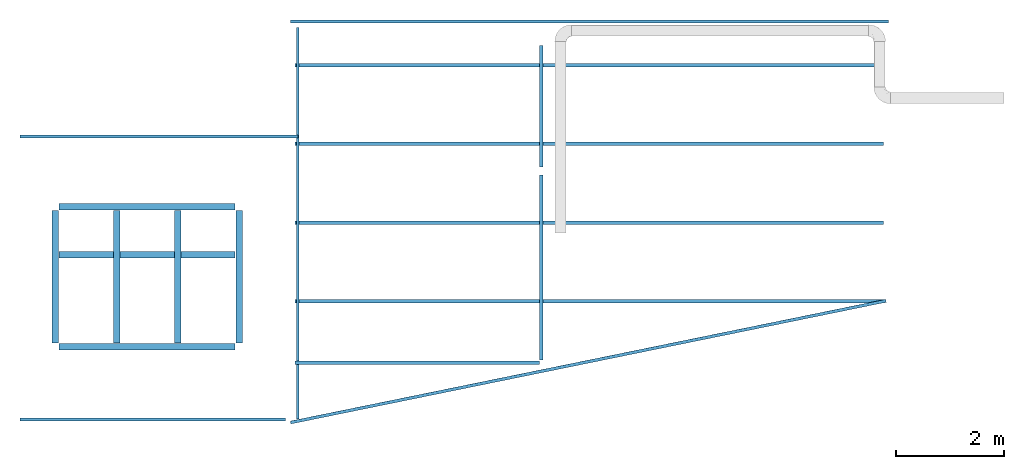
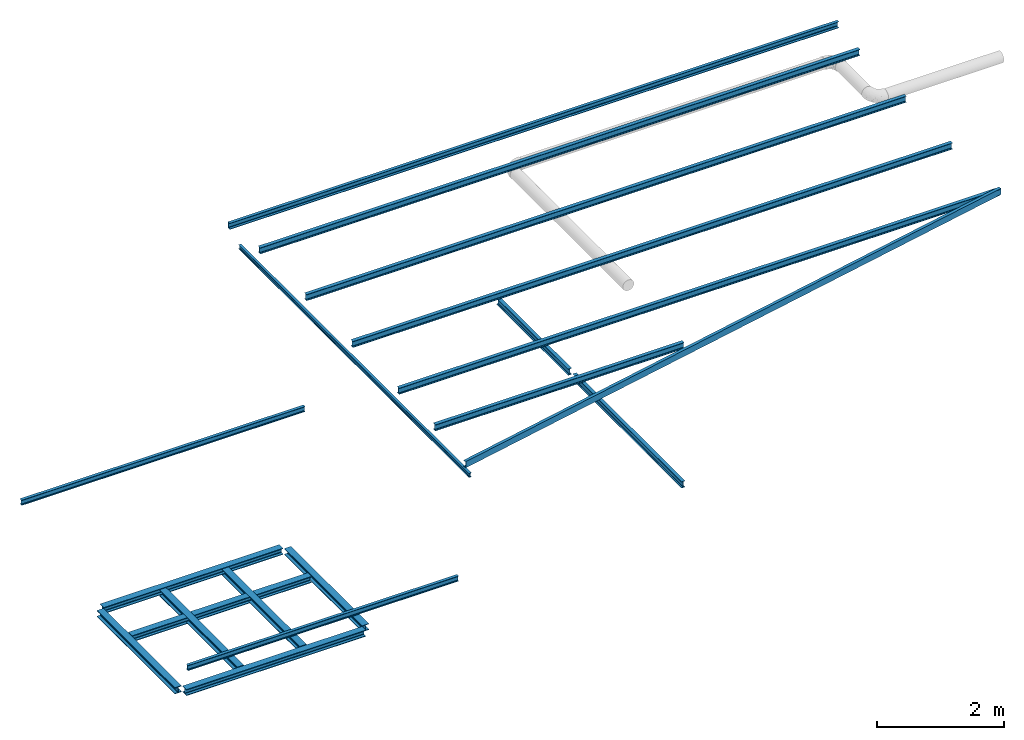
# One storey, part 1 of 2: 15 beams, 4 members.
"""IFC2X3 building model written with IfcOpenShell, lengths in metres."""

from ifc_helpers import new_model, entity, si_unit, converted_unit, derived_unit, direction, frame, frame_2d, origin, place, context, subcontext, project, spatial, polyline, circle_curve, parameter, trimmed, segment, composite_curve, i_section, outline, extrude, source, transform, mapped, material, type_object, type_shapes, element, save


model = new_model("IFC2X3")

# Units and contexts
model_context = context("Model", 3, precision=1e-05, world=origin(), true_north=direction((6.123233995736766e-17, 1.0)))
body_context = subcontext(model_context, "Body", "Model", "MODEL_VIEW")
ifc_project = project(units=[si_unit("LENGTHUNIT", "METRE"), converted_unit("PLANEANGLEUNIT", "DEGREE", entity("IfcPlaneAngleMeasure", 0.017453292519943278), si_unit("PLANEANGLEUNIT", "RADIAN"), dimensions=[0, 0, 0, 0, 0, 0, 0]), si_unit("AREAUNIT", "SQUARE_METRE"), derived_unit("THERMALTRANSMITTANCEUNIT", [(si_unit("MASSUNIT", "GRAM", prefix="KILO"), 1), (si_unit("THERMODYNAMICTEMPERATUREUNIT", "KELVIN"), -1), (si_unit("TIMEUNIT", "SECOND"), -3)])], contexts=[model_context])

# Site, building, storey
site_placement = place(None, origin())
site = spatial("IfcSite", under=ifc_project, at=site_placement, CompositionType="ELEMENT")
building_placement = place(site_placement, origin())
building = spatial("IfcBuilding", under=site, at=building_placement, CompositionType="ELEMENT")
storey_placement = place(building_placement, frame((0.0, 0.0, 8.0952)))
storey = spatial("IfcBuildingStorey", under=building, at=storey_placement, Name="2", CompositionType="ELEMENT", Elevation=8.0952)

# Beams
ifc_material = material(Name="Metal - Steel - 345 MPa")
beam_type_1 = type_object("IfcBeamType", PredefinedType="NOTDEFINED")
beam_1_placement = place(storey_placement, frame((0.30669713519211367, -1.5492589967772536, -2.601933788715456), z_axis=(0.0, 0.0, 1.0), x_axis=(0.0, 1.0, 0.0)))
element("IfcBeam", 1, at=beam_1_placement, inside=storey, type_object=beam_type_1, material=ifc_material, context=body_context, shape_type="SweptSolid", body=[
    extrude(i_section(OverallWidth=0.1200000000000002, OverallDepth=0.11999999999999979, WebThickness=0.006500000000000249, FlangeThickness=0.011000000000001831, FilletRadius=0.012000000000000243, at=frame_2d((0.0, 5.204170427930421e-17), x_axis=(0.0, 1.0))), frame((0.0727626166928101, 0.0, -0.060000000000005854), z_axis=(1.0, 0.0, 0.0), x_axis=(0.0, 0.0, -1.0)), (0.0, 0.0, 1.0), 2.448000000000001),
])
beam_2_placement = place(storey_placement, frame((3.7066971351921287, -1.549258996777253, -2.6019337887154657), z_axis=(0.0, 0.0, 1.0), x_axis=(0.0, 1.0, 0.0)))
element("IfcBeam", 2, at=beam_2_placement, inside=storey, type_object=beam_type_1, material=ifc_material, context=body_context, shape_type="SweptSolid", body=[
    extrude(i_section(OverallWidth=0.12000000000000033, OverallDepth=0.12000000000000088, WebThickness=0.006499999999996505, FlangeThickness=0.011000000000001831, FilletRadius=0.012000000000000306, at=frame_2d((1.0824674490095276e-15, 2.706168622523819e-16), x_axis=(0.0, 1.0))), frame((0.07276261669280956, 0.0, -0.06000000000000477), z_axis=(1.0, 0.0, 0.0), x_axis=(0.0, 0.0, -1.0)), (0.0, 0.0, 1.0), 2.448),
])
beam_3_placement = place(storey_placement, frame((0.3066971351921177, 1.0442662366083677, -2.601933788715456)))
element("IfcBeam", 3, at=beam_3_placement, inside=storey, type_object=beam_type_1, material=ifc_material, context=body_context, shape_type="SweptSolid", body=[
    extrude(i_section(OverallWidth=0.12000000000000033, OverallDepth=0.11999999999999979, WebThickness=0.006499999999999236, FlangeThickness=0.011000000000000749, FilletRadius=0.01200000000000017, at=frame_2d((5.412337245047638e-16, -6.591949208711867e-17), x_axis=(0.0, 1.0))), frame((0.07300000000000653, 0.0, -0.060000000000005854), z_axis=(1.0, 0.0, 0.0), x_axis=(0.0, 0.0, -1.0)), (0.0, 0.0, 1.0), 3.2540000000000013),
])
beam_type_2 = type_object("IfcBeamType", PredefinedType="JOIST")
beam_4_placement = place(storey_placement, frame((0.3066971351921132, -1.5492589967772523, -2.601933788715456)))
element("IfcBeam", 4, at=beam_4_placement, inside=storey, type_object=beam_type_2, material=ifc_material, context=body_context, shape_type="SweptSolid", body=[
    extrude(i_section(OverallWidth=0.12000000000000033, OverallDepth=0.11999999999999979, WebThickness=0.006500000000000146, FlangeThickness=0.011000000000000749, FilletRadius=0.012000000000000148, at=frame_2d((5.412337245047638e-16, 0.0), x_axis=(0.0, 1.0))), frame((0.07300000000000723, 0.0, -0.060000000000005854), z_axis=(1.0, 0.0, 0.0), x_axis=(0.0, 0.0, -1.0)), (0.0, 0.0, 1.0), 3.254000000000001),
])
beam_5_placement = place(storey_placement, frame((0.30669713519211717, 0.1525637485110957, -2.601933788715456)))
element("IfcBeam", 5, at=beam_5_placement, inside=storey, type_object=beam_type_2, material=ifc_material, context=body_context, shape_type="SweptSolid", body=[
    extrude(i_section(OverallWidth=0.1200000000000002, OverallDepth=0.11999999999999979, WebThickness=0.006500000000000079, FlangeThickness=0.011000000000000749, FilletRadius=0.012000000000000195, at=frame_2d((5.412337245047638e-16, 3.469446951953614e-17), x_axis=(0.0, 1.0))), frame((0.07300000000000713, 0.0, -0.060000000000005854), z_axis=(1.0, 0.0, 0.0), x_axis=(0.0, 0.0, -1.0)), (0.0, 0.0, 1.0), 3.254000000000001),
])
beam_6_placement = place(storey_placement, frame((1.4400304685255059, 1.0442662366083675, -2.601933788715459), z_axis=(0.0, 0.0, 1.0), x_axis=(0.0, -1.0, 0.0)))
element("IfcBeam", 6, at=beam_6_placement, inside=storey, type_object=beam_type_2, material=ifc_material, context=body_context, shape_type="SweptSolid", body=[
    extrude(i_section(OverallWidth=0.12000000000000006, OverallDepth=0.12000000000000087, WebThickness=0.006500000000000146, FlangeThickness=0.011000000000001831, FilletRadius=0.012000000000001022, at=frame_2d((0.0, 0.0), x_axis=(0.0, 1.0))), frame((0.07276261669281293, 0.0, -0.060000000000005854), z_axis=(1.0, 0.0, 0.0), x_axis=(0.0, 0.0, -1.0)), (0.0, 0.0, 1.0), 2.448),
])
beam_7_placement = place(storey_placement, frame((2.573363801858818, 1.0442662366083635, -2.6019337887154634), z_axis=(0.0, 0.0, 1.0), x_axis=(0.0, -1.0, 0.0)))
element("IfcBeam", 7, at=beam_7_placement, inside=storey, type_object=beam_type_2, material=ifc_material, context=body_context, shape_type="SweptSolid", body=[
    extrude(i_section(OverallWidth=0.11999999999999979, OverallDepth=0.12000000000000088, WebThickness=0.006500000000003789, FlangeThickness=0.011000000000001831, FilletRadius=0.012000000000000966, at=frame_2d((0.0, 2.706168622523819e-16), x_axis=(0.0, 1.0))), frame((0.07276261669281443, 0.0, -0.060000000000005854), z_axis=(1.0, 0.0, 0.0), x_axis=(0.0, 0.0, -1.0)), (0.0, 0.0, 1.0), 2.448),
])
beam_type_3 = type_object("IfcBeamType", Name="IPE-Beams:IPE100", PredefinedType="JOIST")
beam_8_placement = place(storey_placement, frame((4.846697135192188, 2.3395713760116172, -1.0952000000000013), z_axis=(0.0, 0.0, 1.0), x_axis=(-1.0, 0.0, 0.0)))
element("IfcBeam", 8, at=beam_8_placement, inside=storey, type_object=beam_type_3, material=ifc_material, Name="IPE-Beams:IPE100", ObjectType="IPE-Beams:IPE100", context=body_context, shape_type="SweptSolid", body=[
    extrude(i_section(OverallWidth=0.05500000000000049, OverallDepth=0.1, WebThickness=0.004099999999996608, FlangeThickness=0.00570000000000087, FilletRadius=0.006999999999999106, at=frame_2d((5.412337245047638e-16, 4.0592529337857286e-16), x_axis=(0.0, 1.0))), frame((0.04799999999999634, 0.0, -0.050000000000004874), z_axis=(1.0, 0.0, 0.0), x_axis=(0.0, 0.0, -1.0)), (0.0, 0.0, 1.0), 5.144),
])
beam_9_placement = place(storey_placement, frame((4.961936963576227, -2.889258996777291, -1.0952000000000013), z_axis=(0.0, 0.0, 1.0), x_axis=(-1.0, 0.0, 0.0)))
element("IfcBeam", 9, at=beam_9_placement, inside=storey, type_object=beam_type_3, material=ifc_material, Name="IPE-Beams:IPE100", ObjectType="IPE-Beams:IPE100", context=body_context, shape_type="SweptSolid", body=[
    extrude(i_section(OverallWidth=0.05500000000000049, OverallDepth=0.1, WebThickness=0.004099999999999609, FlangeThickness=0.00570000000000087, FilletRadius=0.006999999999999485, at=frame_2d((5.412337245047638e-16, 2.706168622523819e-16), x_axis=(0.0, 1.0))), frame((0.396619914192016, 0.0, -0.050000000000004874), z_axis=(1.0, 0.0, 0.0), x_axis=(0.0, 0.0, -1.0)), (0.0, 0.0, 1.0), 4.911000000000001),
])
beam_type_4 = type_object("IfcBeamType", Name="U-Channels:UPN120", PredefinedType="BEAM")
beam_10_placement = place(storey_placement, frame((4.699182757982756, 4.479421783554592, 1.1754304129694442)))
element("IfcBeam", 10, at=beam_10_placement, inside=storey, type_object=beam_type_4, material=ifc_material, Name="U-Channels:UPN120", ObjectType="U-Channels:UPN120", context=body_context, shape_type="SweptSolid", body=[
    extrude(outline(composite_curve([segment(polyline([(-0.030523524416621532, -0.059999999999999956), (0.024476475583377313, -0.05999999999999995)]), True, "CONTINUOUS"), segment(polyline([(0.024476475583377844, -0.06000000000000104), (0.02447647558337749, -0.05735437703343096)]), True, "CONTINUOUS"), segment(trimmed(circle_curve(frame_2d((0.01997647558337835, -0.0573543770334309), x_axis=(1.0, 0.0)), 0.004499999999999825), [parameter(0.0)], [parameter(85.42607874010409)], True, "PARAMETER"), True, "CONTINUOUS"), segment(polyline([(0.02033532908365046, -0.052868708280017745), (-0.015241231417167954, -0.05002258343995257)]), True, "CONTINUOUS"), segment(trimmed(circle_curve(frame_2d((-0.01452352441662104, -0.04105124593312735), x_axis=(-0.07974522228286952, -0.9968152785361265)), 0.008999999999999654), [parameter(274.57392125989884)], [parameter(0.0)], True, "PARAMETER"), False, "CONTINUOUS"), segment(polyline([(-0.02352352441662149, -0.04105124593312724), (-0.02352352441662143, 0.041051245933134244)]), True, "CONTINUOUS"), segment(trimmed(circle_curve(frame_2d((-0.014523524416620956, 0.04105124593313628), x_axis=(-1.0, 0.0)), 0.008999999999999307), [parameter(274.573921259893)], [parameter(0.0)], True, "PARAMETER"), False, "CONTINUOUS"), segment(polyline([(-0.015241231417166644, 0.05002258343995939), (0.020335329083650863, 0.05286870828002465)]), True, "CONTINUOUS"), segment(trimmed(circle_curve(frame_2d((0.01997647558337966, 0.05735437703343783), x_axis=(0.07974522228262255, -0.9968152785361463)), 0.004499999999999318), [parameter(0.0)], [parameter(85.42607874011394)], True, "PARAMETER"), True, "CONTINUOUS"), segment(polyline([(0.024476475583378267, 0.057354377033437785), (0.024476475583377826, 0.05999999999999921)]), True, "CONTINUOUS"), segment(polyline([(0.024476475583378367, 0.0599999999999992), (-0.030523524416621563, 0.05999999999999921)]), True, "CONTINUOUS"), segment(polyline([(-0.03052352441662047, 0.06000000000000028), (-0.030523524416622073, -0.05999999999999995)]), True, "CONTINUOUS")], self_intersect=False)), frame((-0.03960000000000182, -0.013915416079771502, -0.06014394364196543), z_axis=(1.0, 0.0, 0.0), x_axis=(0.0, -0.9999487637875227, -0.010122736774470394)), (0.0, 0.0, 1.0), 11.052),
])
beam_11_placement = place(storey_placement, frame((15.672439286939504, -0.7074049188185345, 1.1229228412774654), z_axis=(-0.001986929508695549, -0.00040628908034462657, 0.9999979435180408), x_axis=(-0.9797253379532281, -0.20033509231471072, -0.0020280433154477783)))
element("IfcBeam", 11, at=beam_11_placement, inside=storey, type_object=beam_type_4, material=ifc_material, Name="U-Channels:UPN120", ObjectType="U-Channels:UPN120", context=body_context, shape_type="SweptSolid", body=[
    extrude(outline(composite_curve([segment(polyline([(-0.030523524416621896, -0.060000000000003585), (0.024476475583377552, -0.06000000000000286)]), True, "CONTINUOUS"), segment(polyline([(0.02447647558337796, -0.06000000000000285), (0.024476475583377788, -0.05735437703343218)]), True, "CONTINUOUS"), segment(trimmed(circle_curve(frame_2d((0.019976475583377524, -0.05735437703343206), x_axis=(1.0, 0.0)), 0.004499999999999436), [parameter(0.0)], [parameter(85.42607874010774)], True, "PARAMETER"), True, "CONTINUOUS"), segment(polyline([(0.020335329083650287, -0.05286870828001859), (-0.015241231417167586, -0.0500225834399542)]), True, "CONTINUOUS"), segment(trimmed(circle_curve(frame_2d((-0.014523524416622028, -0.04105124593312943), x_axis=(-0.07974522228281967, -0.9968152785361309)), 0.0089999999999995), [parameter(274.5739212598948)], [parameter(0.0)], True, "PARAMETER"), False, "CONTINUOUS"), segment(polyline([(-0.023523524416622033, -0.0410512459331281), (-0.023523524416621706, 0.04105124593313442)]), True, "CONTINUOUS"), segment(trimmed(circle_curve(frame_2d((-0.014523524416620482, 0.041051245933133106), x_axis=(-1.0, 0.0)), 0.009000000000000412), [parameter(274.5739212599046)], [parameter(0.0)], True, "PARAMETER"), False, "CONTINUOUS"), segment(polyline([(-0.015241231417166603, 0.050022583439958454), (0.020335329083650853, 0.0528687082800245)]), True, "CONTINUOUS"), segment(trimmed(circle_curve(frame_2d((0.019976475583377392, 0.05735437703343663), x_axis=(0.07974522228296779, -0.9968152785361192)), 0.00450000000000044), [parameter(0.0)], [parameter(85.42607874009293)], True, "PARAMETER"), True, "CONTINUOUS"), segment(polyline([(0.024476475583378468, 0.05735437703343652), (0.024476475583378662, 0.05999999999999854)]), True, "CONTINUOUS"), segment(polyline([(0.024476475583378662, 0.05999999999999854), (-0.030523524416620516, 0.0599999999999978)]), True, "CONTINUOUS"), segment(polyline([(-0.030523524416620786, 0.0599999999999978), (-0.03052352441662149, -0.06000000000000358)]), True, "CONTINUOUS")], self_intersect=False)), frame((0.0011698148795877962, -0.015117861478290796, -0.059853011835699084), z_axis=(1.0, 0.0, 0.0), x_axis=(0.0, -0.9999508201683447, 0.009917522102572945)), (0.0, 0.0, 1.0), 11.239000000000004),
])

# Members
member_type_1 = type_object("IfcMemberType", Name="IPE-Beams:IPE120", PredefinedType="PURLIN", material=ifc_material)
shared_shape_1 = source(origin(), body_context, "Body", "SweptSolid", [
    extrude(outline(composite_curve([segment(polyline([(-0.03200000000000017, -0.053699999999999734), (-0.03200000000000017, -0.06000000000000053)]), True, "CONTINUOUS"), segment(polyline([(-0.03200000000000017, -0.06000000000000053), (0.03200000000000007, -0.06000000000000053)]), True, "CONTINUOUS"), segment(polyline([(0.03200000000000007, -0.06000000000000053), (0.03200000000000007, -0.053699999999999734)]), True, "CONTINUOUS"), segment(polyline([(0.03200000000000007, -0.053699999999999734), (0.009199999999999969, -0.053699999999999734)]), True, "CONTINUOUS"), segment(trimmed(circle_curve(frame_2d((0.009199999999999955, -0.046699999999999735), x_axis=(1.0, 0.0)), 0.007000000000000001), [parameter(180.00000000000014)], [parameter(269.9999999999999)], True, "PARAMETER"), False, "CONTINUOUS"), segment(polyline([(0.002199999999999953, -0.046699999999999756), (0.002199999999999953, 0.04670000000000016)]), True, "CONTINUOUS"), segment(trimmed(circle_curve(frame_2d((0.009199999999999955, 0.04670000000000014), x_axis=(1.0, 0.0)), 0.007000000000000001), [parameter(90.00000000000009)], [parameter(179.9999999999999)], True, "PARAMETER"), False, "CONTINUOUS"), segment(polyline([(0.009199999999999969, 0.05370000000000012), (0.03200000000000007, 0.05370000000000012)]), True, "CONTINUOUS"), segment(polyline([(0.03200000000000007, 0.05370000000000012), (0.03200000000000007, 0.059999999999999366)]), True, "CONTINUOUS"), segment(polyline([(0.03200000000000006, 0.059999999999999366), (-0.03199999999999961, 0.059999999999999366)]), True, "CONTINUOUS"), segment(polyline([(-0.03199999999999961, 0.059999999999999366), (-0.03199999999999961, 0.05370000000000012)]), True, "CONTINUOUS"), segment(polyline([(-0.03199999999999961, 0.05370000000000012), (-0.009200000000000121, 0.05370000000000012)]), True, "CONTINUOUS"), segment(trimmed(circle_curve(frame_2d((-0.009200000000000132, 0.04670000000000014), x_axis=(1.0, 0.0)), 0.007000000000000001), [parameter(359.99999999999966)], [parameter(89.99999999999973)], True, "PARAMETER"), False, "CONTINUOUS"), segment(polyline([(-0.002200000000000131, 0.046700000000000116), (-0.002200000000000131, -0.046699999999999735)]), True, "CONTINUOUS"), segment(trimmed(circle_curve(frame_2d((-0.009200000000000132, -0.046699999999999735), x_axis=(1.0, 0.0)), 0.007000000000000001), [parameter(269.9999999999999)], [parameter(0.0)], True, "PARAMETER"), False, "CONTINUOUS"), segment(polyline([(-0.009200000000000121, -0.053699999999999734), (-0.03200000000000017, -0.053699999999999734)]), True, "CONTINUOUS")], self_intersect=False)), frame((-5.4415000000000004, 0.0, 0.0), z_axis=(-1.0, 0.0, 0.0), x_axis=(0.0, -1.0, 0.0)), (0.0, 0.0, -1.0), 10.883000000000001),
])
type_shapes(member_type_1, [shared_shape_1])
for number, where, z_axis, x_axis, name in (
    (12, (10.185582757982754, 3.6620022061465747, 1.1071523914458254), (0.0, -0.010122736774463134, 0.9999487637875228), (1.0, 0.0, 0.0), "IPE-Beams:IPE120"),
    (13, (10.185582757982754, 0.7494052619119264, 1.0776674285514138), (0.0, -0.010122736774463134, 0.9999487637875228), (1.0, 0.0, 0.0), "IPE-Beams:IPE120"),
    (14, (10.185582757982745, 2.2057356170887146, 1.092410232758974), (0.0, -0.010122736774463134, 0.9999487637875228), (1.0, 0.0, 0.0), "IPE-Beams:IPE120"),
):
    element("IfcMember", number, at=place(storey_placement, frame(where, z_axis=z_axis, x_axis=x_axis)), inside=storey, type_object=member_type_1, material=ifc_material, Name=name, ObjectType="IPE-Beams:IPE120", context=body_context, shape_type="MappedRepresentation", body=[
        mapped(shared_shape_1, transform((0.0, 0.0, 0.0), scale=1.0)),
    ])

# Beams
beam_type_5 = type_object("IfcBeamType", Name="IPE-Beams:IPE120", PredefinedType="BEAM")
beam_12_placement = place(storey_placement, frame((15.672439286939504, -0.7074049188185346, 1.1229228412774654), z_axis=(0.0, 0.0, 1.0), x_axis=(-1.0, 0.0, 0.0)))
element("IfcBeam", 15, at=beam_12_placement, inside=storey, type_object=beam_type_5, material=ifc_material, Name="IPE-Beams:IPE120", ObjectType="IPE-Beams:IPE120", context=body_context, shape_type="SweptSolid", body=[
    extrude(outline(composite_curve([segment(polyline([(-0.032000000000001284, -0.05369999999999989), (-0.032000000000001506, -0.060000000000000636)]), True, "CONTINUOUS"), segment(polyline([(-0.03200000000000137, -0.060000000000000636), (0.03199999999999873, -0.06000000000000175)]), True, "CONTINUOUS"), segment(polyline([(0.03199999999999887, -0.06000000000000175), (0.031999999999998946, -0.053700000000001004)]), True, "CONTINUOUS"), segment(polyline([(0.031999999999998946, -0.053700000000001004), (0.009199999999998817, -0.053700000000001004)]), True, "CONTINUOUS"), segment(trimmed(circle_curve(frame_2d((0.00919999999999803, -0.0467000000000004), x_axis=(-1.0, 0.0)), 0.006999999999999009), [parameter(0.0)], [parameter(90.00000000001113)], True, "PARAMETER"), False, "CONTINUOUS"), segment(polyline([(0.0021999999999987967, -0.04669999999999984), (0.00220000000000095, 0.04669999999999986)]), True, "CONTINUOUS"), segment(trimmed(circle_curve(frame_2d((0.009200000000000586, 0.046699999999999305), x_axis=(0.0, 1.0)), 0.0069999999999994685), [parameter(0.0)], [parameter(90.00000000000009)], True, "PARAMETER"), False, "CONTINUOUS"), segment(polyline([(0.009200000000001278, 0.05369999999999881), (0.03200000000000128, 0.053699999999998804)]), True, "CONTINUOUS"), segment(polyline([(0.032000000000001416, 0.053699999999998804), (0.032000000000001486, 0.05999999999999847)]), True, "CONTINUOUS"), segment(polyline([(0.032000000000001486, 0.05999999999999847), (-0.03199999999999822, 0.059999999999999575)]), True, "CONTINUOUS"), segment(polyline([(-0.03199999999999822, 0.059999999999999575), (-0.03199999999999842, 0.05369999999999991)]), True, "CONTINUOUS"), segment(polyline([(-0.03199999999999842, 0.05369999999999991), (-0.009199999999998962, 0.053699999999999914)]), True, "CONTINUOUS"), segment(trimmed(circle_curve(frame_2d((-0.009199999999998017, 0.04670000000000148), x_axis=(1.0, 0.0)), 0.0069999999999989515), [parameter(0.0)], [parameter(90.0000000000212)], True, "PARAMETER"), False, "CONTINUOUS"), segment(polyline([(-0.0021999999999990664, 0.046699999999999846), (-0.0022000000000010848, -0.04669999999999987)]), True, "CONTINUOUS"), segment(trimmed(circle_curve(frame_2d((-0.009200000000000721, -0.046699999999999305), x_axis=(0.0, -1.0)), 0.006999999999999463), [parameter(0.0)], [parameter(90.00000000000009)], True, "PARAMETER"), False, "CONTINUOUS"), segment(polyline([(-0.00920000000000129, -0.053699999999999894), (-0.032000000000001284, -0.05369999999999989)]), True, "CONTINUOUS")], self_intersect=False)), frame((0.033128264478370466, -0.0006073642064693182, -0.05999692582725689), z_axis=(-1.0, 0.0, 0.0), x_axis=(0.0, -0.9999487637875225, 0.01012273677448555)), (0.0, 0.0, -1.0), 10.895000000000001),
])
beam_13_placement = place(storey_placement, frame((9.291497135192111, -1.8443540072264035, 1.1114132152199017), z_axis=(0.0, 0.0, 1.0), x_axis=(-1.0, 0.0, 0.0)))
element("IfcBeam", 16, at=beam_13_placement, inside=storey, type_object=beam_type_5, material=ifc_material, Name="IPE-Beams:IPE120", ObjectType="IPE-Beams:IPE120", context=body_context, shape_type="SweptSolid", body=[
    extrude(outline(composite_curve([segment(polyline([(-0.03199999999999899, -0.053700000000000324), (-0.03199999999999877, -0.06000000000000107)]), True, "CONTINUOUS"), segment(polyline([(-0.03199999999999877, -0.06000000000000107), (0.0320000000000016, -0.05999999999999915)]), True, "CONTINUOUS"), segment(polyline([(0.0320000000000016, -0.05999999999999915), (0.03200000000000138, -0.0536999999999984)]), True, "CONTINUOUS"), segment(polyline([(0.03200000000000137, -0.053699999999999484), (0.009200000000001245, -0.053699999999999484)]), True, "CONTINUOUS"), segment(trimmed(circle_curve(frame_2d((0.009199999999999844, -0.046699999999999964), x_axis=(-1.0, 0.0)), 0.006999999999998942), [parameter(0.0)], [parameter(90.0000000000201)], True, "PARAMETER"), False, "CONTINUOUS"), segment(polyline([(0.002200000000000882, -0.046699999999999735), (0.002199999999998605, 0.04670000000000105)]), True, "CONTINUOUS"), segment(trimmed(circle_curve(frame_2d((0.009199999999998107, 0.04670000000000084), x_axis=(0.0, 1.0)), 0.006999999999999453), [parameter(0.0)], [parameter(90.00000000000227)], True, "PARAMETER"), False, "CONTINUOUS"), segment(polyline([(0.009199999999998602, 0.05370000000000033), (0.03199999999999873, 0.05370000000000141)]), True, "CONTINUOUS"), segment(polyline([(0.03199999999999873, 0.05370000000000141), (0.0319999999999985, 0.06000000000000108)]), True, "CONTINUOUS"), segment(polyline([(0.03199999999999822, 0.06), (-0.03200000000000133, 0.059999999999999144)]), True, "CONTINUOUS"), segment(polyline([(-0.03200000000000135, 0.05999999999999806), (-0.032000000000001104, 0.053699999999999484)]), True, "CONTINUOUS"), segment(polyline([(-0.032000000000001104, 0.053699999999999484), (-0.009200000000001506, 0.05370000000000057)]), True, "CONTINUOUS"), segment(trimmed(circle_curve(frame_2d((-0.009200000000000364, 0.046700000000002136), x_axis=(1.0, 0.0)), 0.0069999999999989515), [parameter(0.0)], [parameter(90.0000000000201)], True, "PARAMETER"), False, "CONTINUOUS"), segment(polyline([(-0.002200000000001412, 0.04670000000000083), (-0.0021999999999991245, -0.04669999999999889)]), True, "CONTINUOUS"), segment(trimmed(circle_curve(frame_2d((-0.009199999999998628, -0.04669999999999866), x_axis=(0.0, -1.0)), 0.006999999999999447), [parameter(0.0)], [parameter(90.00000000000227)], True, "PARAMETER"), False, "CONTINUOUS"), segment(polyline([(-0.009199999999998872, -0.05370000000000033), (-0.03199999999999899, -0.053700000000000324)]), True, "CONTINUOUS")], self_intersect=False)), frame((0.03215718860462186, -0.0006073642064693182, -0.05999692582725689), z_axis=(-1.0, 0.0, 0.0), x_axis=(0.0, -0.9999487637875231, 0.010122736774438002)), (0.0, 0.0, -1.0), 4.515),
])
beam_14_placement = place(storey_placement, frame((9.291497135192152, 1.700510500280605, -1.6752771077183575), z_axis=(0.0, 0.0, 1.0), x_axis=(0.0, -1.0, 0.0)))
element("IfcBeam", 17, at=beam_14_placement, inside=storey, type_object=beam_type_5, material=ifc_material, Name="IPE-Beams:IPE120", ObjectType="IPE-Beams:IPE120", context=body_context, shape_type="SweptSolid", body=[
    extrude(i_section(OverallWidth=0.06399999999999953, OverallDepth=0.11999999999999979, WebThickness=0.004400000000000083, FlangeThickness=0.006300000000000734, FilletRadius=0.006999999999998254, at=frame_2d((5.412337245047638e-16, 3.247402347028583e-15), x_axis=(0.0, 1.0))), frame((0.07299413392219276, 0.0, 0.0), z_axis=(1.0, 0.0, 0.0), x_axis=(0.0, 0.0, -1.0)), (0.0, 0.0, 1.0), 3.419000000000001),
])
beam_type_6 = type_object("IfcBeamType", Name="IPE-Beams:IPE120", PredefinedType="NOTDEFINED")
beam_15_placement = place(storey_placement, frame((9.291497135192156, 4.101560722664287, -1.675277107718365), z_axis=(0.0, 0.0, 1.0), x_axis=(0.0, -1.0, 0.0)))
element("IfcBeam", 18, at=beam_15_placement, inside=storey, type_object=beam_type_6, material=ifc_material, Name="IPE-Beams:IPE120", ObjectType="IPE-Beams:IPE120", context=body_context, shape_type="SweptSolid", body=[
    extrude(i_section(OverallWidth=0.06399999999999953, OverallDepth=0.11999999999999979, WebThickness=0.004400000000000083, FlangeThickness=0.006300000000000734, FilletRadius=0.006999999999998254, at=frame_2d((5.412337245047638e-16, 1.0824674490095276e-15), x_axis=(0.0, 1.0))), frame((0.07302511119184282, 0.0, 0.0), z_axis=(1.0, 0.0, 0.0), x_axis=(0.0, 0.0, -1.0)), (0.0, 0.0, 1.0), 2.2550000000000003),
])

# Member
member_type_2 = type_object("IfcMemberType", Name="IPE-Beams:IPE80", PredefinedType="BRACE", material=ifc_material)
shared_shape_2 = source(origin(), body_context, "Body", "SweptSolid", [
    extrude(outline(composite_curve([segment(polyline([(-0.02300000000000016, -0.03479999999999974), (-0.02300000000000016, -0.040000000000000535)]), True, "CONTINUOUS"), segment(polyline([(-0.02300000000000016, -0.040000000000000535), (0.02300000000000007, -0.040000000000000535)]), True, "CONTINUOUS"), segment(polyline([(0.02300000000000007, -0.040000000000000535), (0.02300000000000007, -0.03479999999999974)]), True, "CONTINUOUS"), segment(polyline([(0.02300000000000007, -0.03479999999999974), (0.00689999999999996, -0.03479999999999974)]), True, "CONTINUOUS"), segment(trimmed(circle_curve(frame_2d((0.0068999999999999504, -0.029799999999999743), x_axis=(1.0, 0.0)), 0.004999999999999999), [parameter(180.0)], [parameter(269.99999999999966)], True, "PARAMETER"), False, "CONTINUOUS"), segment(polyline([(0.001899999999999951, -0.029799999999999764), (0.001899999999999951, 0.029800000000000156)]), True, "CONTINUOUS"), segment(trimmed(circle_curve(frame_2d((0.0068999999999999504, 0.029800000000000135), x_axis=(1.0, 0.0)), 0.004999999999999999), [parameter(90.00000000000009)], [parameter(180.0000000000001)], True, "PARAMETER"), False, "CONTINUOUS"), segment(polyline([(0.006899999999999958, 0.034800000000000136), (0.02300000000000007, 0.034800000000000136)]), True, "CONTINUOUS"), segment(polyline([(0.02300000000000007, 0.034800000000000136), (0.02300000000000007, 0.0399999999999994)]), True, "CONTINUOUS"), segment(polyline([(0.023000000000000072, 0.0399999999999994), (-0.022999999999999604, 0.0399999999999994)]), True, "CONTINUOUS"), segment(polyline([(-0.022999999999999604, 0.0399999999999994), (-0.022999999999999604, 0.034800000000000136)]), True, "CONTINUOUS"), segment(polyline([(-0.022999999999999604, 0.034800000000000136), (-0.006900000000000121, 0.034800000000000136)]), True, "CONTINUOUS"), segment(trimmed(circle_curve(frame_2d((-0.006900000000000131, 0.02980000000000014), x_axis=(1.0, 0.0)), 0.004999999999999999), [parameter(359.9999999999996)], [parameter(89.99999999999973)], True, "PARAMETER"), False, "CONTINUOUS"), segment(polyline([(-0.0019000000000001323, 0.029800000000000142), (-0.0019000000000001323, -0.029799999999999743)]), True, "CONTINUOUS"), segment(trimmed(circle_curve(frame_2d((-0.006900000000000131, -0.029799999999999743), x_axis=(1.0, 0.0)), 0.004999999999999999), [parameter(269.9999999999999)], [parameter(0.0)], True, "PARAMETER"), False, "CONTINUOUS"), segment(polyline([(-0.006900000000000121, -0.03479999999999974), (-0.02300000000000016, -0.03479999999999974)]), True, "CONTINUOUS")], self_intersect=False)), frame((-3.6215, 0.0, 0.0), z_axis=(-1.0, 0.0, 0.0), x_axis=(0.0, -1.0, 0.0)), (0.0, 0.0, -1.0), 7.243),
])
type_shapes(member_type_2, [shared_shape_2])
member_placement = place(storey_placement, frame((4.793289717821109, 0.7362682040335816, 0.7394936347516472), z_axis=(0.0, 0.0, 1.0), x_axis=(0.0, 1.0, 0.0)))
element("IfcMember", 19, at=member_placement, inside=storey, type_object=member_type_2, material=ifc_material, Name="IPE-Beams:IPE80", ObjectType="IPE-Beams:IPE80", context=body_context, shape_type="MappedRepresentation", body=[
    mapped(shared_shape_2, transform((0.0, 0.0, 0.0), scale=1.0)),
])

save(model, "model.ifc")
